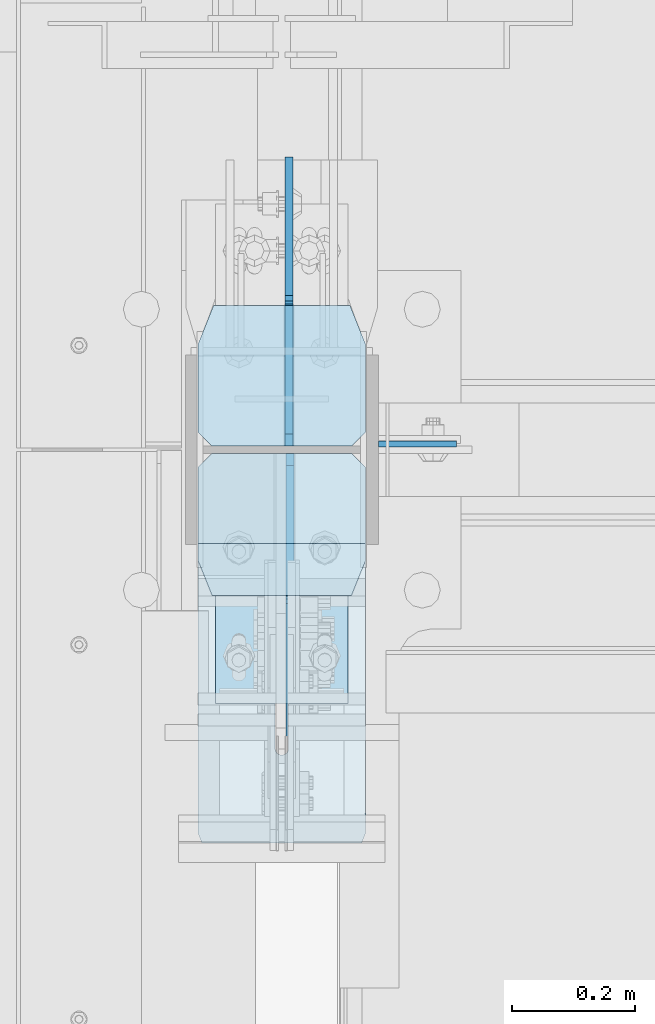
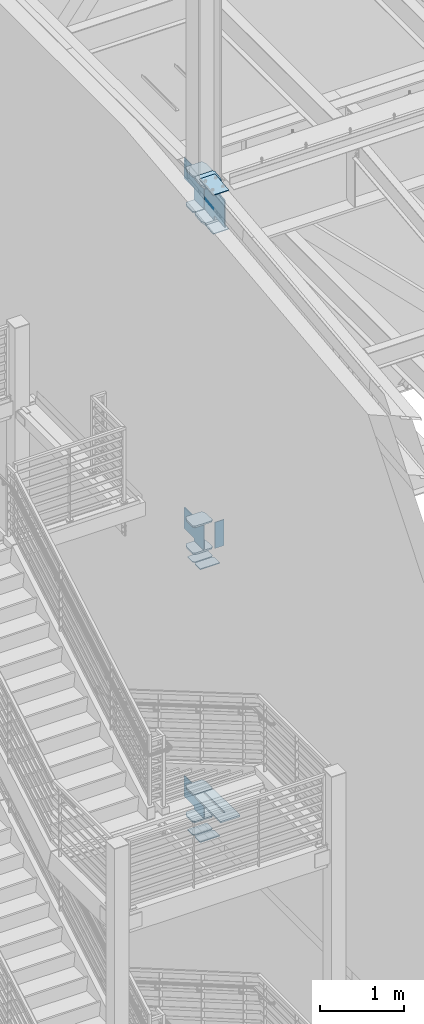
# One storey, part 1059 of 1179: 20 plates, 1 element without a shape of its own.
"""IFC2X3 building model written with IfcOpenShell, lengths in millimetres."""

from ifc_helpers import new_model, si_unit, frame, origin_with_axes, place, context, subcontext, project, spatial, faceted_brep, material, type_object, element, aggregate, save


model = new_model("IFC2X3")

# Units and contexts
model_context = context("Model", 3, precision=1e-05, world=origin_with_axes())
body_context = subcontext(model_context, "Body", "Model", "MODEL_VIEW")
ifc_project = project(units=[si_unit("LENGTHUNIT", "METRE", prefix="MILLI"), si_unit("AREAUNIT", "SQUARE_METRE"), si_unit("VOLUMEUNIT", "CUBIC_METRE"), si_unit("MASSUNIT", "GRAM", prefix="KILO"), si_unit("TIMEUNIT", "SECOND"), si_unit("PLANEANGLEUNIT", "RADIAN"), si_unit("SOLIDANGLEUNIT", "STERADIAN"), si_unit("THERMODYNAMICTEMPERATUREUNIT", "DEGREE_CELSIUS"), si_unit("LUMINOUSINTENSITYUNIT", "LUMEN")], contexts=[model_context])

# Site, building, storey
site_placement = place(None, origin_with_axes())
site = spatial("IfcSite", under=ifc_project, at=site_placement, CompositionType="ELEMENT")
building_placement = place(site_placement, origin_with_axes())
building = spatial("IfcBuilding", under=site, at=building_placement, Name="Undefined", CompositionType="ELEMENT")
storey_placement = place(building_placement, origin_with_axes())
storey = spatial("IfcBuildingStorey", under=building, at=storey_placement, Name="Undefined", CompositionType="ELEMENT", Elevation=0.0)

# Assembly, plates
assembly_placement = place(storey_placement, origin_with_axes())
assembly = element("IfcElementAssembly", 1, at=assembly_placement, inside=storey, Name="COLUMN", AssemblyPlace="NOTDEFINED", PredefinedType="RIGID_FRAME")
ifc_material_1 = material(Name="STEEL/A36")
plate_type_1 = type_object("IfcPlateType", PredefinedType="NOTDEFINED")
plate_1_placement = place(assembly_placement, frame((588.9625, 34401.125, 7975.6), z_axis=(1.0, 0.0, 0.0), x_axis=(0.0, 0.0, -1.0)))
plate_1 = element("IfcPlate", 2, at=plate_1_placement, type_object=plate_type_1, material=ifc_material_1, Name="PLATE", context=body_context, shape_type="Brep", body=[
    faceted_brep([(0.0, -4.76249999999709, 0.0), (0.0, -4.76249999999709, 127.0), (0.0, 4.76249999999709, 127.0), (0.0, 4.76249999999709, 0.0), (381.0, -4.76249999999709, 127.0), (381.0, 4.76249999999709, 127.0), (381.0, -4.76249999999999, 8.66293703438714e-11), (381.0, 4.76249999999999, 8.66293703438714e-11)], [[[0, 1, 2, 3]], [[1, 4, 5, 2]], [[4, 6, 7, 5]], [[6, 0, 3, 7]], [[5, 7, 3, 2]], [[6, 4, 1, 0]]]),
])
ifc_material_2 = material(Name="STEEL/A572-GR.50")
plate_type_2 = type_object("IfcPlateType", PredefinedType="NOTDEFINED")
plate_2_placement = place(assembly_placement, frame((295.275012207031, 33751.616998869, 4090.9875), z_axis=(0.0, 1.0, 0.0), x_axis=(1.0, 0.0, 0.0)))
plate_2 = element("IfcPlate", 3, at=plate_2_placement, type_object=plate_type_2, material=ifc_material_2, Name="PLATE", context=body_context, shape_type="Brep", body=[
    faceted_brep([(125.412487792972, -11.1125000000002, 633.633001130984), (125.412487792968, -11.1125000000002, 153.987500190735), (125.412487792968, 11.1125000000002, 153.987500190735), (125.412487792972, 11.1125000000002, 633.633001130984), (126.258376502454, -11.1125000000002, 149.734930475586), (126.258376502454, 11.1125000000002, 149.734930475586), (128.667263742896, -11.1125000000002, 146.12977594993), (128.667263742896, 11.1125000000002, 146.12977594993), (132.272418268556, -11.1125000000002, 143.720888709488), (132.272418268556, 11.1125000000002, 143.720888709488), (136.524987602239, -11.1125000000002, 142.875), (136.524987602239, 11.1125000000002, 142.875), (140.777557317386, -11.1125000000002, 143.720888709488), (140.777557317386, 11.1125000000002, 143.720888709488), (144.382711843045, -11.1125000000002, 146.12977594993), (144.382711843045, 11.1125000000002, 146.12977594993), (146.791599083488, -11.1125000000002, 149.734930475586), (146.791599083488, 11.1125000000002, 149.734930475586), (147.637487792974, -11.1125000000002, 153.987500190735), (147.637487792974, 11.1125000000002, 153.987500190735), (147.637487792977, -11.1125000000002, 633.633001130984), (147.637487792977, 11.1125000000002, 633.633001130984), (0.0, -11.1125000000002, 611.408000749514), (22.2250003814697, -11.1125000000002, 633.633001130984), (22.2250003814697, 11.1125000000002, 633.633001130984), (0.0, 11.1125000000002, 611.408000749514), (0.0, -11.1125000000002, 15.875), (0.0, 11.1125000000002, 15.875), (6.34999990463257, -11.1125000000002, 0.0), (6.34999990463257, 11.1125000000002, 0.0), (266.699987888336, -11.1125000000002, 0.0), (266.699987888336, 11.1125000000002, 0.0), (273.049987792969, -11.1125000000002, 15.875), (273.049987792969, 11.1125000000002, 15.875), (273.049987792969, -11.1125000000002, 611.408000749514), (273.049987792969, 11.1125000000002, 611.408000749514), (250.824987411499, -11.1125000000002, 633.633001130984), (250.824987411499, 11.1125000000002, 633.633001130984)], [[[0, 1, 2, 3]], [[4, 5, 2, 1]], [[6, 7, 5, 4]], [[8, 9, 7, 6]], [[10, 11, 9, 8]], [[12, 13, 11, 10]], [[14, 15, 13, 12]], [[16, 17, 15, 14]], [[18, 19, 17, 16]], [[20, 21, 19, 18]], [[22, 23, 24, 25]], [[26, 22, 25, 27]], [[28, 26, 27, 29]], [[30, 28, 29, 31]], [[32, 30, 31, 33]], [[34, 32, 33, 35]], [[36, 34, 35, 37]], [[16, 14, 12, 10, 8, 6, 4, 1, 0, 23, 22, 26, 28, 30, 32, 34, 36, 20, 18]], [[24, 23, 0, 3]], [[37, 35, 33, 31, 29, 27, 25, 24, 3, 2, 5, 7, 9, 11, 13, 15, 17, 19, 21]], [[36, 37, 21, 20]]]),
])
plate_type_3 = type_object("IfcPlateType", PredefinedType="NOTDEFINED")
plate_3_placement = place(assembly_placement, frame((568.325, 34626.55, 12590.4625), z_axis=(-1.0, 0.0, 0.0), x_axis=(0.0, -1.0, 0.0)))
plate_3 = element("IfcPlate", 4, at=plate_3_placement, type_object=plate_type_3, material=ifc_material_2, Name="PLATE", context=body_context, shape_type="Brep", body=[
    faceted_brep([(0.0, -11.1125000000002, 25.3999996185303), (0.0, -11.1125000000002, 247.650000381473), (0.0, 11.1125000000002, 247.650000381473), (0.0, 11.1125000000002, 25.3999996185303), (63.5, -11.1125000000002, 273.050000000003), (63.5, 11.1125000000002, 273.050000000003), (206.374999618529, -11.1125000000002, 273.050000000003), (206.374999618529, 11.1125000000002, 273.050000000003), (228.599999999999, -11.1125000000002, 250.824999618533), (228.599999999999, 11.1125000000002, 250.824999618533), (228.599999999999, -11.1125000000002, 22.2250003814697), (228.599999999999, 11.1125000000002, 22.2250003814697), (206.374999618529, -11.1125000000002, 0.0), (206.374999618529, 11.1125000000002, 0.0), (63.5, -11.1125000000002, 0.0), (63.5, 11.1125000000002, 0.0)], [[[0, 1, 2, 3]], [[1, 4, 5, 2]], [[4, 6, 7, 5]], [[6, 8, 9, 7]], [[8, 10, 11, 9]], [[10, 12, 13, 11]], [[12, 14, 15, 13]], [[14, 0, 3, 15]], [[5, 7, 9, 11, 13, 15, 3, 2]], [[14, 12, 10, 8, 6, 4, 1, 0]]]),
])
plate_4_placement = place(assembly_placement, frame((568.325, 34626.55, 13107.9875), z_axis=(-1.0, 0.0, 0.0), x_axis=(0.0, -1.0, 0.0)))
plate_4 = element("IfcPlate", 5, at=plate_4_placement, type_object=plate_type_3, material=ifc_material_2, Name="PLATE", context=body_context, shape_type="Brep", body=[
    faceted_brep([(0.0, -11.1125000000002, 25.3999996185303), (0.0, -11.1125000000002, 247.650000381473), (0.0, 11.1125000000002, 247.650000381473), (0.0, 11.1125000000002, 25.3999996185303), (63.5, -11.1125000000002, 273.050000000003), (63.5, 11.1125000000002, 273.050000000003), (206.374999618529, -11.1125000000002, 273.050000000003), (206.374999618529, 11.1125000000002, 273.050000000003), (228.599999999999, -11.1125000000002, 250.824999618533), (228.599999999999, 11.1125000000002, 250.824999618533), (228.599999999999, -11.1125000000002, 22.2250003814697), (228.599999999999, 11.1125000000002, 22.2250003814697), (206.374999618529, -11.1125000000002, 0.0), (206.374999618529, 11.1125000000002, 0.0), (63.5, -11.1125000000002, 0.0), (63.5, 11.1125000000002, 0.0)], [[[0, 1, 2, 3]], [[1, 4, 5, 2]], [[4, 6, 7, 5]], [[6, 8, 9, 7]], [[8, 10, 11, 9]], [[10, 12, 13, 11]], [[12, 14, 15, 13]], [[14, 0, 3, 15]], [[5, 7, 9, 11, 13, 15, 3, 2]], [[14, 12, 10, 8, 6, 4, 1, 0]]]),
])
plate_5_placement = place(assembly_placement, frame((568.325, 34626.55, 7608.8875), z_axis=(-1.0, 0.0, 0.0), x_axis=(0.0, -1.0, 0.0)))
plate_5 = element("IfcPlate", 6, at=plate_5_placement, type_object=plate_type_3, material=ifc_material_2, Name="PLATE", context=body_context, shape_type="Brep", body=[
    faceted_brep([(0.0, -11.1125000000002, 247.650000381473), (63.5, -11.1125000000002, 273.050000000003), (63.5, 11.1125000000002, 273.050000000003), (0.0, 11.1125000000002, 247.650000381473), (63.5, -11.1125000000002, 0.0), (0.0, -11.1125000000002, 25.3999996185303), (0.0, 11.1125000000002, 25.3999996185303), (63.5, 11.1125000000002, 0.0), (206.374999618529, -11.1125000000002, 273.050000000003), (206.374999618529, 11.1125000000002, 273.050000000003), (228.599999999999, -11.1125000000002, 250.824999618533), (228.599999999999, 11.1125000000002, 250.824999618533), (228.599999999999, -11.1125000000002, 22.2250003814697), (228.599999999999, 11.1125000000002, 22.2250003814697), (206.374999618529, -11.1125000000002, 0.0), (206.374999618529, 11.1125000000002, 0.0)], [[[0, 1, 2, 3]], [[4, 5, 6, 7]], [[5, 0, 3, 6]], [[1, 8, 9, 2]], [[8, 10, 11, 9]], [[10, 12, 13, 11]], [[12, 14, 15, 13]], [[14, 4, 7, 15]], [[2, 9, 11, 13, 15, 7, 6, 3]], [[4, 14, 12, 10, 8, 1, 0, 5]]]),
])
plate_6_placement = place(assembly_placement, frame((568.325, 34626.55, 8002.5875), z_axis=(-1.0, 0.0, 0.0), x_axis=(0.0, -1.0, 0.0)))
plate_6 = element("IfcPlate", 7, at=plate_6_placement, type_object=plate_type_3, material=ifc_material_2, Name="PLATE", context=body_context, shape_type="Brep", body=[
    faceted_brep([(0.0, -11.1125000000002, 247.650000381473), (63.5, -11.1125000000002, 273.050000000003), (63.5, 11.1125000000002, 273.050000000003), (0.0, 11.1125000000002, 247.650000381473), (63.5, -11.1125000000002, 0.0), (0.0, -11.1125000000002, 25.3999996185303), (0.0, 11.1125000000002, 25.3999996185303), (63.5, 11.1125000000002, 0.0), (206.374999618529, -11.1125000000002, 273.050000000003), (206.374999618529, 11.1125000000002, 273.050000000003), (228.599999999999, -11.1125000000002, 250.824999618533), (228.599999999999, 11.1125000000002, 250.824999618533), (228.599999999999, -11.1125000000002, 22.2250003814697), (228.599999999999, 11.1125000000002, 22.2250003814697), (206.374999618529, -11.1125000000002, 0.0), (206.374999618529, 11.1125000000002, 0.0)], [[[0, 1, 2, 3]], [[4, 5, 6, 7]], [[5, 0, 3, 6]], [[1, 8, 9, 2]], [[8, 10, 11, 9]], [[10, 12, 13, 11]], [[12, 14, 15, 13]], [[14, 4, 7, 15]], [[2, 9, 11, 13, 15, 7, 6, 3]], [[4, 14, 12, 10, 8, 1, 0, 5]]]),
])
plate_7_placement = place(assembly_placement, frame((568.325, 34626.55, 3694.1125), z_axis=(-1.0, 0.0, 0.0), x_axis=(0.0, -1.0, 0.0)))
plate_7 = element("IfcPlate", 8, at=plate_7_placement, type_object=plate_type_3, material=ifc_material_2, Name="PLATE", context=body_context, shape_type="Brep", body=[
    faceted_brep([(0.0, -11.1125000000002, 247.650000381473), (63.5, -11.1125000000002, 273.050000000003), (63.5, 11.1125000000002, 273.050000000003), (0.0, 11.1125000000002, 247.650000381473), (63.5, -11.1125000000002, 0.0), (0.0, -11.1125000000002, 25.3999996185303), (0.0, 11.1125000000002, 25.3999996185303), (63.5, 11.1125000000002, 0.0), (206.374999618529, -11.1125000000002, 0.0), (206.374999618529, 11.1125000000002, 0.0), (228.599999999999, -11.1125000000002, 22.2250003814697), (228.599999999999, 11.1125000000002, 22.2250003814697), (228.599999999999, -11.1125000000002, 250.824999618533), (228.599999999999, 11.1125000000002, 250.824999618533), (206.374999618529, -11.1125000000002, 273.050000000003), (206.374999618529, 11.1125000000002, 273.050000000003)], [[[0, 1, 2, 3]], [[4, 5, 6, 7]], [[8, 4, 7, 9]], [[10, 8, 9, 11]], [[12, 10, 11, 13]], [[14, 12, 13, 15]], [[4, 8, 10, 12, 14, 1, 0, 5]], [[5, 0, 3, 6]], [[2, 15, 13, 11, 9, 7, 6, 3]], [[1, 14, 15, 2]]]),
])
plate_8_placement = place(assembly_placement, frame((568.325, 34626.55, 4090.9875), z_axis=(-1.0, 0.0, 0.0), x_axis=(0.0, -1.0, 0.0)))
plate_8 = element("IfcPlate", 9, at=plate_8_placement, type_object=plate_type_3, material=ifc_material_2, Name="PLATE", context=body_context, shape_type="Brep", body=[
    faceted_brep([(0.0, -11.1125000000002, 247.650000381473), (63.5, -11.1125000000002, 273.050000000003), (63.5, 11.1125000000002, 273.050000000003), (0.0, 11.1125000000002, 247.650000381473), (63.5, -11.1125000000002, 0.0), (0.0, -11.1125000000002, 25.3999996185303), (0.0, 11.1125000000002, 25.3999996185303), (63.5, 11.1125000000002, 0.0), (206.374999618529, -11.1125000000002, 0.0), (206.374999618529, 11.1125000000002, 0.0), (228.599999999999, -11.1125000000002, 22.2250003814697), (228.599999999999, 11.1125000000002, 22.2250003814697), (228.599999999999, -11.1125000000002, 250.824999618533), (228.599999999999, 11.1125000000002, 250.824999618533), (206.374999618529, -11.1125000000002, 273.050000000003), (206.374999618529, 11.1125000000002, 273.050000000003)], [[[0, 1, 2, 3]], [[4, 5, 6, 7]], [[8, 4, 7, 9]], [[10, 8, 9, 11]], [[12, 10, 11, 13]], [[14, 12, 13, 15]], [[4, 8, 10, 12, 14, 1, 0, 5]], [[5, 0, 3, 6]], [[2, 15, 13, 11, 9, 7, 6, 3]], [[1, 14, 15, 2]]]),
])
plate_type_4 = type_object("IfcPlateType", PredefinedType="NOTDEFINED")
plate_9_placement = place(assembly_placement, frame((568.325, 34385.25, 7486.65), z_axis=(-1.0, 0.0, 0.0), x_axis=(0.0, -1.0, 0.0)))
plate_9 = element("IfcPlate", 10, at=plate_9_placement, type_object=plate_type_4, material=ifc_material_1, Name="PLATE", context=body_context, shape_type="Brep", body=[
    faceted_brep([(0.0, -6.34999999999854, 22.2250003814697), (0.0, -6.35000000000036, 250.82499961853), (0.0, 6.35000000000036, 250.82499961853), (0.0, 6.34999999999854, 22.2250003814697), (22.2250003814697, -6.35000000000036, 273.05), (22.2250003814697, 6.35000000000036, 273.05), (146.050003051758, -6.35000000000036, 273.049987792969), (146.050003051758, 6.35000000000036, 273.049987792969), (146.050003051758, -6.35000000000036, 0.0), (146.050003051758, 6.35000000000036, 0.0), (22.2250003814697, -6.34999999999854, 0.0), (22.2250003814697, 6.34999999999854, 0.0)], [[[0, 1, 2, 3]], [[1, 4, 5, 2]], [[4, 6, 7, 5]], [[6, 8, 9, 7]], [[8, 10, 11, 9]], [[10, 0, 3, 11]], [[5, 7, 9, 11, 3, 2]], [[10, 8, 6, 4, 1, 0]]]),
])
plate_10_placement = place(assembly_placement, frame((568.325, 34544.0, 7486.65), z_axis=(-1.0, 0.0, 0.0), x_axis=(0.0, -1.0, 0.0)))
plate_10 = element("IfcPlate", 11, at=plate_10_placement, type_object=plate_type_4, material=ifc_material_1, Name="PLATE", context=body_context, shape_type="Brep", body=[
    faceted_brep([(0.0, -6.34999999999854, 0.0), (0.0, -6.34999999999991, 273.05), (0.0, 6.34999999999991, 273.05), (0.0, 6.34999999999854, 0.0), (123.824999618599, -6.34999999999991, 273.05), (123.824999618599, 6.34999999999991, 273.05), (146.050000000068, -6.34999999999991, 250.82499961853), (146.050000000068, 6.34999999999991, 250.82499961853), (146.050000000068, -6.34999999999991, 22.2250003814697), (146.050000000068, 6.34999999999991, 22.2250003814697), (123.824999618599, -6.34999999999991, 0.0), (123.824999618599, 6.34999999999991, 0.0)], [[[0, 1, 2, 3]], [[1, 4, 5, 2]], [[4, 6, 7, 5]], [[6, 8, 9, 7]], [[8, 10, 11, 9]], [[10, 0, 3, 11]], [[5, 7, 9, 11, 3, 2]], [[10, 8, 6, 4, 1, 0]]]),
])
plate_11_placement = place(assembly_placement, frame((568.325, 34385.25, 3505.2), z_axis=(-1.0, 0.0, 0.0), x_axis=(0.0, -1.0, 0.0)))
plate_11 = element("IfcPlate", 12, at=plate_11_placement, type_object=plate_type_4, material=ifc_material_1, Name="PLATE", context=body_context, shape_type="Brep", body=[
    faceted_brep([(0.0, -6.34999999999854, 22.2250003814697), (0.0, -6.35000000000036, 250.82499961853), (0.0, 6.35000000000036, 250.82499961853), (0.0, 6.34999999999854, 22.2250003814697), (22.2250003814697, -6.35000000000036, 273.05), (22.2250003814697, 6.35000000000036, 273.05), (146.050003051758, -6.35000000000036, 273.049987792969), (146.050003051758, 6.35000000000036, 273.049987792969), (146.050003051758, -6.35000000000036, 0.0), (146.050003051758, 6.35000000000036, 0.0), (22.2250003814697, -6.34999999999854, 0.0), (22.2250003814697, 6.34999999999854, 0.0)], [[[0, 1, 2, 3]], [[1, 4, 5, 2]], [[4, 6, 7, 5]], [[6, 8, 9, 7]], [[8, 10, 11, 9]], [[10, 0, 3, 11]], [[5, 7, 9, 11, 3, 2]], [[10, 8, 6, 4, 1, 0]]]),
])
plate_12_placement = place(assembly_placement, frame((568.325, 34544.0, 3505.2), z_axis=(-1.0, 0.0, 0.0), x_axis=(0.0, -1.0, 0.0)))
plate_12 = element("IfcPlate", 13, at=plate_12_placement, type_object=plate_type_4, material=ifc_material_1, Name="PLATE", context=body_context, shape_type="Brep", body=[
    faceted_brep([(0.0, -6.34999999999854, 0.0), (0.0, -6.34999999999991, 273.05), (0.0, 6.34999999999991, 273.05), (0.0, 6.34999999999854, 0.0), (123.824999618599, -6.34999999999991, 273.05), (123.824999618599, 6.34999999999991, 273.05), (146.050000000068, -6.34999999999991, 250.82499961853), (146.050000000068, 6.34999999999991, 250.82499961853), (146.050000000068, -6.34999999999991, 22.2250003814697), (146.050000000068, 6.34999999999991, 22.2250003814697), (123.824999618599, -6.34999999999991, 0.0), (123.824999618599, 6.34999999999991, 0.0)], [[[0, 1, 2, 3]], [[1, 4, 5, 2]], [[4, 6, 7, 5]], [[6, 8, 9, 7]], [[8, 10, 11, 9]], [[10, 0, 3, 11]], [[5, 7, 9, 11, 3, 2]], [[10, 8, 6, 4, 1, 0]]]),
])
plate_type_5 = type_object("IfcPlateType", PredefinedType="NOTDEFINED")
plate_13_placement = place(assembly_placement, frame((443.70625, 34397.9499999871, 12620.625), z_axis=(0.0, 0.707106781186542, 0.707106781186553), x_axis=(0.0, 0.707106781186553, -0.707106781186542)))
plate_13 = element("IfcPlate", 14, at=plate_13_placement, type_object=plate_type_5, material=ifc_material_2, Name="PLATE", context=body_context, shape_type="Brep", body=[
    faceted_brep([(0.0, -6.34999999999854, 0.0), (-323.289220358607, -6.35000000000002, 323.289220358594), (-323.289220358607, 6.35000000000002, 323.289220358594), (0.0, 6.34999999999854, 0.0), (-323.289220358678, -6.35000000000002, 350.229988721738), (-323.289220358678, 6.35000000000002, 350.229988721738), (-175.11499436176, -6.35000000000002, 498.404214718663), (-175.11499436176, 6.35000000000002, 498.404214718663), (-172.869930061752, -6.35000000000002, 496.159150418658), (-172.869930061752, 6.35000000000002, 496.159150418658), (-164.629577125441, -6.35000000000002, 490.653122617703), (-164.629577125441, 6.35000000000002, 490.653122617703), (-154.909418089363, -6.35000000000002, 488.719662772513), (-154.909418089363, 6.35000000000002, 488.719662772513), (-145.189259053284, -6.35000000000002, 490.653122617674), (-145.189259053284, 6.35000000000002, 490.653122617674), (-136.948906116993, -6.35000000000002, 496.159150418614), (-136.948906116993, 6.35000000000002, 496.159150418614), (15.7154482101414, -6.35000000000002, 648.823504745764), (15.7154482101414, 6.35000000000002, 648.823504745764), (231.241595115887, -6.35000000000002, 433.297357840042), (231.241595115887, 6.35000000000002, 433.297357840042), (78.5772407887489, -6.35000000000002, 280.633003512892), (78.5772407887489, 6.35000000000002, 280.633003512892), (73.071212987812, -6.35000000000002, 272.392650576599), (73.071212987812, 6.35000000000002, 272.392650576599), (71.1377531426533, -6.35000000000002, 262.672491540528), (71.1377531426533, 6.35000000000002, 262.672491540528), (73.0712129878375, -6.35000000000002, 252.952332504443), (73.0712129878375, 6.35000000000002, 252.952332504443), (78.577240788798, -6.35000000000002, 244.711979568136), (78.577240788798, 6.35000000000002, 244.711979568136), (175.114994360907, -6.34999999999854, 148.174225997692), (175.114994360907, 6.34999999999854, 148.174225997692), (26.9407683631471, -6.34999999999854, -6.91215973347425e-11), (26.9407683631471, 6.34999999999854, -6.91215973347425e-11)], [[[0, 1, 2, 3]], [[1, 4, 5, 2]], [[4, 6, 7, 5]], [[6, 8, 9, 7]], [[8, 10, 11, 9]], [[10, 12, 13, 11]], [[12, 14, 15, 13]], [[14, 16, 17, 15]], [[16, 18, 19, 17]], [[18, 20, 21, 19]], [[20, 22, 23, 21]], [[22, 24, 25, 23]], [[24, 26, 27, 25]], [[26, 28, 29, 27]], [[28, 30, 31, 29]], [[30, 32, 33, 31]], [[32, 34, 35, 33]], [[34, 0, 3, 35]], [[5, 7, 9, 11, 13, 15, 17, 19, 21, 23, 25, 27, 29, 31, 33, 35, 3, 2]], [[34, 32, 30, 28, 26, 24, 22, 20, 18, 16, 14, 12, 10, 8, 6, 4, 1, 0]]]),
])
plate_type_6 = type_object("IfcPlateType", PredefinedType="NOTDEFINED")
plate_14_placement = place(assembly_placement, frame((323.850003041492, 33978.9780990307, 12527.2985446927), z_axis=(1.0, 0.0, 0.0), x_axis=(0.0, 0.993676146336441, 0.112284087038017)))
plate_14 = element("IfcPlate", 15, at=plate_14_placement, type_object=plate_type_6, material=ifc_material_2, Name="PLATE", context=body_context, shape_type="Brep", body=[
    faceted_brep([(0.0, -6.34999999999854, 0.0), (0.0, -6.350000000004, 215.899993896484), (0.0, 6.35000000000582, 215.899993896484), (0.0, 6.34999999999854, 0.0), (330.200000001782, -6.34999999994034, 215.899993896483), (330.200000001782, 6.35000000006767, 215.899993896483), (330.200000001782, -6.34999999994034, -1.47792889038101e-12), (330.200000001782, 6.35000000006767, -1.47792889038101e-12)], [[[0, 1, 2, 3]], [[1, 4, 5, 2]], [[4, 6, 7, 5]], [[6, 0, 3, 7]], [[5, 7, 3, 2]], [[6, 4, 1, 0]]]),
])
plate_15_placement = place(assembly_placement, frame((323.850003040412, 33977.5935641146, 13092.6935588728), z_axis=(1.0, 0.0, 0.0), x_axis=(0.0, 0.993676146336441, 0.112284087038017)))
plate_15 = element("IfcPlate", 16, at=plate_15_placement, type_object=plate_type_6, material=ifc_material_2, Name="PLATE", context=body_context, shape_type="Brep", body=[
    faceted_brep([(0.0, -6.34999999999854, 0.0), (0.0, -6.350000000004, 215.899993896484), (0.0, 6.35000000000582, 215.899993896484), (0.0, 6.34999999999854, 0.0), (330.200000001782, -6.34999999994034, 215.899993896483), (330.200000001782, 6.35000000006767, 215.899993896483), (330.200000001782, -6.34999999994034, -1.47792889038101e-12), (330.200000001782, 6.35000000006767, -1.47792889038101e-12)], [[[0, 1, 2, 3]], [[1, 4, 5, 2]], [[4, 6, 7, 5]], [[6, 0, 3, 7]], [[5, 7, 3, 2]], [[6, 4, 1, 0]]]),
])
plate_type_7 = type_object("IfcPlateType", PredefinedType="NOTDEFINED")
plate_16_placement = place(assembly_placement, frame((295.275000000078, 34150.1815305206, 12567.3222175609), z_axis=(1.0, 0.0, 0.0), x_axis=(0.0, 0.993676146336441, 0.112284087038017)))
plate_16 = element("IfcPlate", 17, at=plate_16_placement, type_object=plate_type_7, material=ifc_material_2, Name="PLATE", context=body_context, shape_type="Brep", body=[
    faceted_brep([(212.724999619088, -14.2875000001641, 4.54747350886464e-13), (63.5000000001965, -14.2875000000422, 0.0), (63.5000000002037, 14.2874999999422, 0.0), (212.724999619095, 14.2874999998221, 4.54747350886464e-13), (234.95000000127, -14.2875000001786, 22.2250003814702), (234.950000001292, 14.2874999998039, 22.2250003814702), (234.950000007964, -14.2875000001823, 250.825000381337), (234.950000007979, 14.2874999998039, 250.825000381337), (212.724999627098, -14.2875000001623, 273.049999999897), (212.724999627106, 14.2874999998221, 273.049999999897), (63.5000000082073, -14.2875000000404, 273.049999999896), (63.5000000082146, 14.2874999999422, 273.049999999896), (5.77466625680245, 14.2874999999894, 249.959866846452), (2.54572914389428, -14.2874999999913, 248.66829202071), (2.54572914389428, -14.2874999999913, 24.3817079765539), (5.77466625680245, 14.2874999999894, 23.0901331507811)], [[[0, 1, 2, 3]], [[4, 0, 3, 5]], [[6, 4, 5, 7]], [[8, 6, 7, 9]], [[10, 8, 9, 11]], [[10, 11, 12, 13]], [[1, 0, 4, 6, 8, 10, 13, 14]], [[2, 1, 14, 15]], [[11, 9, 7, 5, 3, 2, 15, 12]], [[14, 13, 12, 15]]]),
])
plate_17_placement = place(assembly_placement, frame((295.275000000071, 34150.1815305201, 13091.5178581985), z_axis=(1.0, 0.0, 0.0), x_axis=(0.0, 0.993676146336441, 0.112284087038017)))
plate_17 = element("IfcPlate", 18, at=plate_17_placement, type_object=plate_type_7, material=ifc_material_2, Name="PLATE", context=body_context, shape_type="Brep", body=[
    faceted_brep([(212.724999619088, -14.2875000001641, 4.54747350886464e-13), (63.5000000001965, -14.2875000000422, 0.0), (63.5000000002037, 14.2874999999422, 0.0), (212.724999619095, 14.2874999998221, 4.54747350886464e-13), (234.95000000127, -14.2875000001786, 22.2250003814702), (234.950000001292, 14.2874999998039, 22.2250003814702), (234.950000007964, -14.2875000001823, 250.825000381337), (234.950000007979, 14.2874999998039, 250.825000381337), (212.724999627098, -14.2875000001623, 273.049999999897), (212.724999627106, 14.2874999998221, 273.049999999897), (63.5000000082073, -14.2875000000404, 273.049999999896), (63.5000000082146, 14.2874999999422, 273.049999999896), (5.77466625680245, 14.2874999999894, 249.959866846452), (2.54572914389428, -14.2874999999913, 248.66829202071), (2.54572914389428, -14.2874999999913, 24.3817079765539), (5.77466625680245, 14.2874999999894, 23.0901331507811)], [[[0, 1, 2, 3]], [[4, 0, 3, 5]], [[6, 4, 5, 7]], [[8, 6, 7, 9]], [[10, 8, 9, 11]], [[10, 11, 12, 13]], [[1, 0, 4, 6, 8, 10, 13, 14]], [[2, 1, 14, 15]], [[11, 9, 7, 5, 3, 2, 15, 12]], [[14, 13, 12, 15]]]),
])
plate_type_8 = type_object("IfcPlateType", PredefinedType="NOTDEFINED")
plate_18_placement = place(assembly_placement, frame((445.293750095369, 34385.2499999998, 12627.313069999), z_axis=(0.0, -0.743858433013958, 0.668337214012522), x_axis=(0.0, -0.668337214012522, -0.743858433013957)))
plate_18 = element("IfcPlate", 19, at=plate_18_placement, type_object=plate_type_8, material=ifc_material_2, Name="PLATE", context=body_context, shape_type="Brep", body=[
    faceted_brep([(0.0, -6.34999999999854, 0.0), (-340.375392921102, -6.34999999999854, 305.818327405632), (-340.375392921102, 6.34999999999854, 305.818327405632), (0.0, 6.34999999999854, 0.0), (-340.032744244661, -6.35000000000002, 331.120178276982), (-340.032744244661, 6.35000000000002, 331.120178276982), (-180.612432254758, -6.35000000000002, 472.730528344626), (-180.612432254758, 6.35000000000002, 472.730528344626), (-178.904815940139, -6.35000000000002, 471.196280052714), (-178.904815940139, 6.35000000000002, 471.196280052714), (-171.547730228256, -6.35000000000002, 466.688782088011), (-171.547730228256, 6.35000000000002, 466.688782088011), (-163.067037537945, -6.35000000000002, 465.100670137868), (-163.067037537945, 6.35000000000002, 465.100670137868), (-154.577480600994, -6.35000000000002, 466.640693218229), (-154.577480600994, 6.35000000000002, 466.640693218229), (-147.1949673081, -6.35000000000002, 471.106423343754), (-147.1949673081, 6.35000000000002, 471.106423343754), (27.2404745111817, -6.35000000000002, 626.054457705886), (27.2404745111817, 6.35000000000002, 626.054457705886), (321.961311035324, -6.35000000000002, 361.255546993463), (321.961311035324, 6.35000000000002, 361.255546993463), (152.88740433798, -6.35000000000002, 211.070073035593), (152.88740433798, 6.35000000000002, 211.070073035593), (147.561239654864, -6.35000000000002, 204.431711365782), (147.561239654864, 6.35000000000002, 204.431711365782), (144.72698969526, -6.35000000000002, 196.406569431998), (144.72698969526, 6.35000000000002, 196.406569431998), (144.702872241545, -6.35000000000002, 187.895676750308), (144.702872241545, 6.35000000000002, 187.895676750308), (147.491595100993, -6.35000000000002, 179.854600907853), (147.491595100993, 6.35000000000002, 179.854600907853), (152.780052084414, -6.35000000000002, 173.18616041361), (152.780052084414, 6.35000000000002, 173.18616041361), (187.923887132867, -6.35000000000002, 141.610350067647), (187.923887132867, 6.35000000000002, 141.610350067647), (28.5035613092805, -6.35000000000002, -1.04591890703887e-11), (28.5035613092805, 6.35000000000002, -1.04591890703887e-11)], [[[0, 1, 2, 3]], [[1, 4, 5, 2]], [[4, 6, 7, 5]], [[6, 8, 9, 7]], [[8, 10, 11, 9]], [[10, 12, 13, 11]], [[12, 14, 15, 13]], [[14, 16, 17, 15]], [[16, 18, 19, 17]], [[18, 20, 21, 19]], [[20, 22, 23, 21]], [[22, 24, 25, 23]], [[24, 26, 27, 25]], [[26, 28, 29, 27]], [[28, 30, 31, 29]], [[30, 32, 33, 31]], [[32, 34, 35, 33]], [[34, 36, 37, 35]], [[36, 0, 3, 37]], [[5, 7, 9, 11, 13, 15, 17, 19, 21, 23, 25, 27, 29, 31, 33, 35, 37, 3, 2]], [[36, 34, 32, 30, 28, 26, 24, 22, 20, 18, 16, 14, 12, 10, 8, 6, 4, 1, 0]]]),
])
plate_type_9 = type_object("IfcPlateType", PredefinedType="NOTDEFINED")
plate_19_placement = place(assembly_placement, frame((443.706250000001, 34397.949999999, 7639.0500034064), z_axis=(0.0, 0.707106781186542, 0.707106781186553), x_axis=(0.0, 0.707106781186553, -0.707106781186542)))
plate_19 = element("IfcPlate", 20, at=plate_19_placement, type_object=plate_type_9, material=ifc_material_2, Name="PLATE", context=body_context, shape_type="Brep", body=[
    faceted_brep([(0.0, -6.34999999999854, 0.0), (-235.731724934591, -6.35000000000002, 235.731721421089), (-235.731724934591, 6.35000000000002, 235.731721421089), (0.0, 6.34999999999854, 0.0), (-235.731724934656, -6.35000000000002, 262.67248958346), (-235.731724934656, 6.35000000000002, 262.67248958346), (-87.5574986365136, -6.35000000000002, 410.846713673389), (-87.5574986365136, 6.35000000000002, 410.846713673389), (-85.3124343197815, -6.35000000000002, 408.601649390112), (-85.3124343197815, 6.35000000000002, 408.601649390112), (-77.072081342445, -6.35000000000002, 403.095621650566), (-77.072081342445, 6.35000000000002, 403.095621650566), (-67.3519222919531, -6.35000000000002, 401.162161877812), (-67.3519222919531, 6.35000000000002, 401.162161877812), (-57.6317632702812, -6.35000000000002, 403.095621795397), (-57.6317632702812, 6.35000000000002, 403.095621795397), (-49.3914103750103, -6.35000000000002, 408.601649657729), (-49.3914103750103, 6.35000000000002, 408.601649657729), (103.272946260589, -6.35000000000002, 561.266008567964), (103.272946260589, 6.35000000000002, 561.266008567964), (318.799094772221, -6.35000000000002, 345.739863268682), (318.799094772221, 6.35000000000002, 345.739863268682), (166.134738136639, -6.35000000000002, 193.075504358469), (166.134738136639, 6.35000000000002, 193.075504358469), (160.628710397086, -6.35000000000002, 184.835151381158), (160.628710397086, 6.35000000000002, 184.835151381158), (158.695250624347, -6.35000000000002, 175.114992330684), (158.695250624347, 6.35000000000002, 175.114992330684), (160.628710541958, -6.35000000000002, 165.394833309019), (160.628710541958, 6.35000000000002, 165.394833309019), (166.134738404326, -6.35000000000002, 157.154480413748), (166.134738404326, 6.35000000000002, 157.154480413748), (175.114994360907, -6.34999999999854, 148.174225997692), (175.114994360907, 6.34999999999854, 148.174225997692), (26.9407683631471, -6.34999999999854, -6.91215973347425e-11), (26.9407683631471, 6.34999999999854, -6.91215973347425e-11)], [[[0, 1, 2, 3]], [[1, 4, 5, 2]], [[4, 6, 7, 5]], [[6, 8, 9, 7]], [[8, 10, 11, 9]], [[10, 12, 13, 11]], [[12, 14, 15, 13]], [[14, 16, 17, 15]], [[16, 18, 19, 17]], [[18, 20, 21, 19]], [[20, 22, 23, 21]], [[22, 24, 25, 23]], [[24, 26, 27, 25]], [[26, 28, 29, 27]], [[28, 30, 31, 29]], [[30, 32, 33, 31]], [[32, 34, 35, 33]], [[34, 0, 3, 35]], [[5, 7, 9, 11, 13, 15, 17, 19, 21, 23, 25, 27, 29, 31, 33, 35, 3, 2]], [[34, 32, 30, 28, 26, 24, 22, 20, 18, 16, 14, 12, 10, 8, 6, 4, 1, 0]]]),
])
plate_type_10 = type_object("IfcPlateType", PredefinedType="NOTDEFINED")
plate_20_placement = place(assembly_placement, frame((443.70625, 34397.9500000087, 3724.275), z_axis=(0.0, 0.707106781186542, 0.707106781186553), x_axis=(0.0, 0.707106781186553, -0.707106781186542)))
plate_20 = element("IfcPlate", 21, at=plate_20_placement, type_object=plate_type_10, material=ifc_material_2, Name="PLATE", context=body_context, shape_type="Brep", body=[
    faceted_brep([(0.0, -6.34999999999854, 0.0), (-237.976787208419, -6.34999999999854, 237.976787208414), (-237.976787208419, 6.34999999999854, 237.976787208414), (0.0, 6.34999999999854, 0.0), (-237.976787208489, -6.34999999999854, 264.917555571561), (-237.976787208489, 6.34999999999854, 264.917555571561), (-89.8025612115634, -6.34999999999854, 413.09178156849), (-89.8025612115634, 6.34999999999854, 413.09178156849), (-87.5574986365136, -6.35000000000002, 410.846713673389), (-87.5574986365136, 6.35000000000002, 410.846713673389), (-79.3171439752477, -6.34999999999854, 405.340689467515), (-79.3171439752477, 6.34999999999854, 405.340689467515), (-69.5969849391658, -6.34999999999854, 403.407229622333), (-69.5969849391658, 6.34999999999854, 403.407229622333), (-59.8768259030876, -6.34999999999854, 405.340689467494), (-59.8768259030876, 6.34999999999854, 405.340689467494), (-51.6364729667966, -6.34999999999854, 410.84671726843), (-51.6364729667966, 6.34999999999854, 410.84671726843), (101.027881360342, -6.34999999999854, 563.511071595573), (101.027881360342, 6.34999999999854, 563.511071595573), (316.554028266077, -6.34999999999854, 347.984924689843), (316.554028266077, 6.34999999999854, 347.984924689843), (163.889673938938, -6.34999999999854, 195.320570362701), (163.889673938938, 6.34999999999854, 195.320570362701), (158.383646138001, -6.34999999999854, 187.080217426408), (158.383646138001, 6.34999999999854, 187.080217426408), (156.450186292839, -6.34999999999854, 177.360058390334), (156.450186292839, 6.34999999999854, 177.360058390334), (158.383646138027, -6.34999999999854, 167.639899354248), (158.383646138027, 6.34999999999854, 167.639899354248), (163.889673938986, -6.34999999999854, 159.399546417944), (163.889673938986, 6.34999999999854, 159.399546417944), (175.114994360907, -6.34999999999854, 148.174225997692), (175.114994360907, 6.34999999999854, 148.174225997692), (26.9407683631471, -6.34999999999854, -6.91215973347425e-11), (26.9407683631471, 6.34999999999854, -6.91215973347425e-11)], [[[0, 1, 2, 3]], [[1, 4, 5, 2]], [[4, 6, 7, 5]], [[6, 8, 9, 7]], [[8, 10, 11, 9]], [[10, 12, 13, 11]], [[12, 14, 15, 13]], [[14, 16, 17, 15]], [[16, 18, 19, 17]], [[18, 20, 21, 19]], [[20, 22, 23, 21]], [[22, 24, 25, 23]], [[24, 26, 27, 25]], [[26, 28, 29, 27]], [[28, 30, 31, 29]], [[30, 32, 33, 31]], [[32, 34, 35, 33]], [[34, 0, 3, 35]], [[5, 7, 9, 11, 13, 15, 17, 19, 21, 23, 25, 27, 29, 31, 33, 35, 3, 2]], [[34, 32, 30, 28, 26, 24, 22, 20, 18, 16, 14, 12, 10, 8, 6, 4, 1, 0]]]),
])
aggregate(assembly, [plate_2, plate_16, plate_17, plate_18, plate_14, plate_15, plate_3, plate_4, plate_13, plate_9, plate_10, plate_1, plate_5, plate_6, plate_19, plate_7, plate_8, plate_20, plate_11, plate_12])

save(model, "model.ifc")
